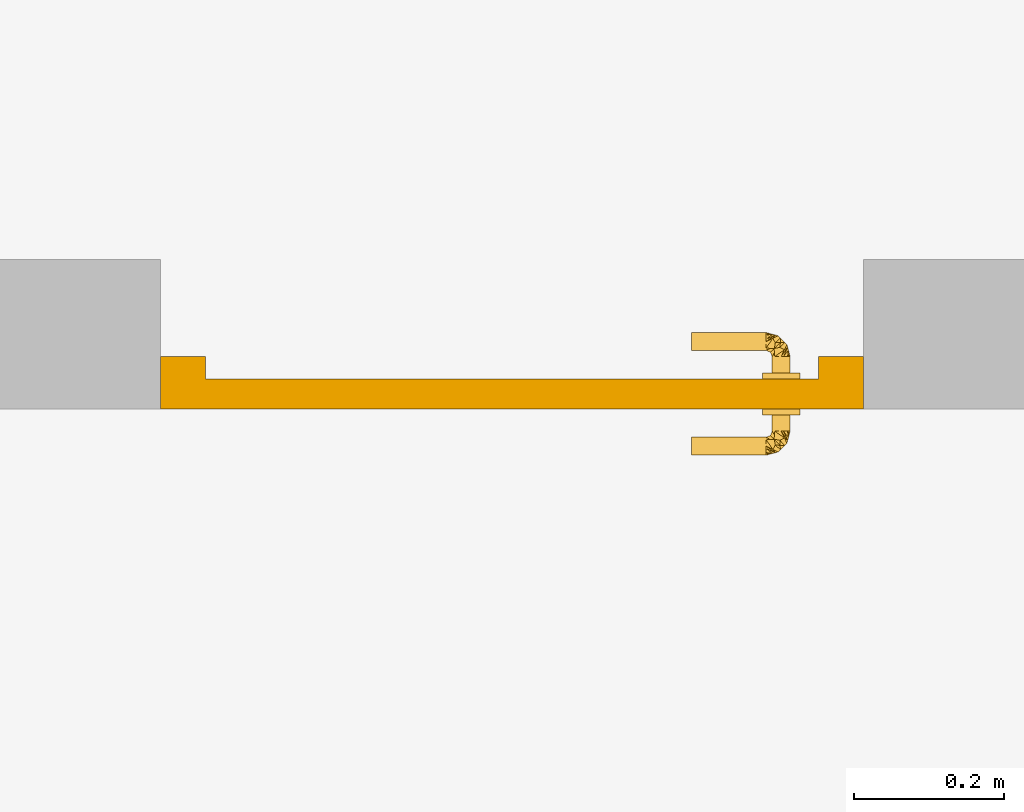
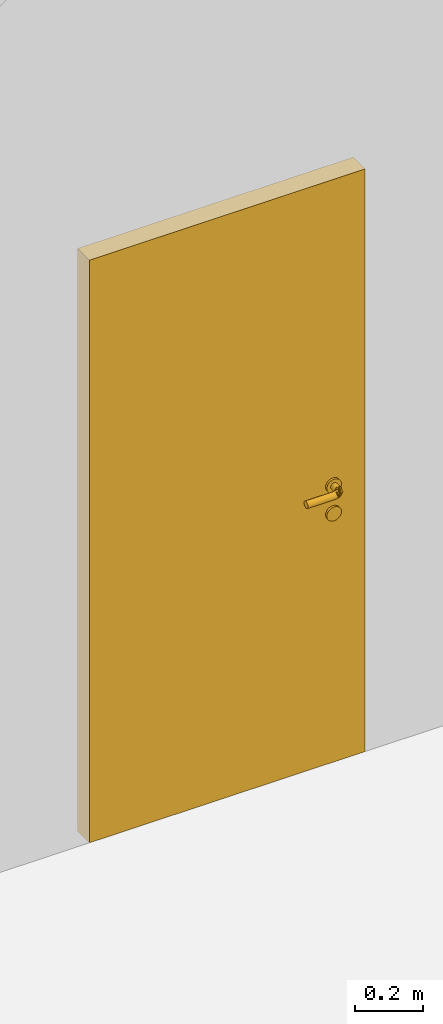
# One storey, part 3 of 4: 1 door.
"""IFC2X3 building model written with IfcOpenShell, lengths in millimetres."""

from ifc_helpers import new_model, entity, si_unit, converted_unit, derived_unit, direction, frame, origin, place, context, subcontext, project, spatial, faceted_brep, source, transform, mapped, material, material_list, type_object, type_shapes, element, save


model = new_model("IFC2X3")

# Units and contexts
model_context = context("Model", 3, precision=0.01, world=origin(), true_north=direction((6.123233995736766e-17, 1.0)))
body_context = subcontext(model_context, "Body", "Model", "MODEL_VIEW")
ifc_project = project(units=[si_unit("LENGTHUNIT", "METRE", prefix="MILLI"), si_unit("AREAUNIT", "SQUARE_METRE"), si_unit("VOLUMEUNIT", "CUBIC_METRE"), converted_unit("PLANEANGLEUNIT", "DEGREE", entity("IfcPlaneAngleMeasure", 0.017453292519943278), si_unit("PLANEANGLEUNIT", "RADIAN"), dimensions=[0, 0, 0, 0, 0, 0, 0]), derived_unit("THERMALTRANSMITTANCEUNIT", [(si_unit("MASSUNIT", "GRAM", prefix="KILO"), 1), (si_unit("THERMODYNAMICTEMPERATUREUNIT", "KELVIN"), -1), (si_unit("TIMEUNIT", "SECOND"), -3)])], contexts=[model_context])

# Site, building, storey
site_placement = place(None, origin())
site = spatial("IfcSite", under=ifc_project, at=site_placement, CompositionType="ELEMENT")
building_placement = place(site_placement, origin())
building = spatial("IfcBuilding", under=site, at=building_placement, CompositionType="ELEMENT")
storey_placement = place(building_placement, origin())
storey = spatial("IfcBuildingStorey", under=building, at=storey_placement, CompositionType="ELEMENT", Elevation=0.0)

# Door
ifc_material_1 = material()
ifc_material_2 = material()
ifc_material_list = material_list([ifc_material_1, ifc_material_2])
door_style = type_object("IfcDoorStyle", ConstructionType="USERDEFINED", OperationType="NOTDEFINED", ParameterTakesPrecedence=False, Sizeable=False, material=ifc_material_list)
shared_shape = source(origin(), body_context, "Body", "Brep", [
    faceted_brep([(121.59110991546477, -492.0, 996.8941714587709), (121.59110991546477, -470.0, 996.8941714587709), (122.0, -470.0, 1000.0), (122.0, -492.0, 1000.0), (122.0, -570.0, 1000.0), (121.59110991546484, -570.0, 996.894171458771), (121.59110991546477, -548.0, 996.8941714587709), (122.0, -548.0, 1000.0), (120.39230484540924, -492.0, 994.0), (120.39230484540924, -470.0, 994.0), (120.39230484540931, -570.0, 994.0), (120.39230484540924, -548.0, 994.0), (118.48528137423456, -470.0, 991.5147186257626), (118.4852813742345, -492.0, 991.5147186257626), (116.0, -492.0, 989.6076951545878), (116.0, -470.0, 989.607695154588), (118.48528137423456, -570.0, 991.5147186257626), (116.0, -570.0, 989.6076951545878), (116.0, -548.0, 989.6076951545878), (118.4852813742345, -548.0, 991.5147186257626), (113.10582854122617, -492.0, 988.4088900845322), (113.10582854122624, -470.0, 988.4088900845322), (113.10582854122612, -570.0, 988.4088900845322), (113.10582854122617, -548.0, 988.4088900845322), (110.0, -492.0, 988.0), (110.0, -470.0, 988.0), (110.0, -570.0, 988.0), (110.0, -548.0, 988.0), (104.0, -492.0, 989.607695154588), (104.0, -470.0, 989.6076951545878), (106.89417145876577, -470.0, 988.4088900845322), (106.89417145876577, -492.0, 988.4088900845322), (106.8941714587655, -570.0, 988.4088900845325), (104.0, -570.0, 989.607695154588), (104.0, -548.0, 989.607695154588), (106.89417145876577, -548.0, 988.4088900845322), (101.51471862575745, -492.0, 991.5147186257626), (101.51471862575745, -470.0, 991.5147186257626), (101.51471862575724, -570.0, 991.5147186257627), (101.51471862575745, -548.0, 991.5147186257626), (99.60769515458277, -470.0, 994.0), (99.6076951545827, -492.0, 994.0), (98.40889008452717, -492.0, 996.8941714587709), (98.40889008452717, -470.0, 996.8941714587709), (99.60769515458257, -570.0, 994.0), (98.4088900845271, -570.0, 996.894171458771), (98.40889008452717, -548.0, 996.8941714587709), (99.6076951545827, -548.0, 994.0), (98.0, -492.0, 1000.0), (98.0, -470.0, 1000.0), (98.0, -570.0, 1000.0), (98.0, -548.0, 1000.0), (98.4088900845271, -492.0, 1003.1058285412312), (98.4088900845271, -470.0, 1003.1058285412312), (98.40889008452717, -570.0, 1003.1058285412314), (98.4088900845271, -548.0, 1003.1058285412312), (99.60769515458257, -492.0, 1006.0), (99.60769515458263, -470.0, 1006.0), (99.60769515458263, -570.0, 1006.0), (99.60769515458257, -548.0, 1006.0), (101.51471862575724, -470.0, 1008.4852813742397), (101.51471862575724, -492.0, 1008.4852813742397), (104.0, -492.0, 1010.3923048454144), (104.0, -470.0, 1010.3923048454144), (101.51471862575724, -548.0, 1008.4852813742397), (101.51471862575731, -570.0, 1008.4852813742397), (104.0, -570.0, 1010.3923048454144), (104.0, -548.0, 1010.3923048454144), (106.8941714587655, -492.0, 1011.5911099154699), (106.89417145876557, -470.0, 1011.5911099154699), (106.89417145876543, -570.0, 1011.5911099154699), (106.8941714587655, -548.0, 1011.5911099154699), (110.0, -492.0, 1012.0), (110.0, -470.0, 1012.0), (110.0, -570.0, 1012.0), (110.0, -548.0, 1012.0), (116.0, -492.0, 1010.3923048454145), (116.0, -470.0, 1010.3923048454145), (113.10582854122605, -470.0, 1011.59110991547), (113.10582854122597, -492.0, 1011.59110991547), (116.0, -570.0, 1010.3923048454146), (116.0, -548.0, 1010.3923048454145), (113.10582854122597, -548.0, 1011.59110991547), (113.10582854122585, -570.0, 1011.59110991547), (118.48528137423436, -492.0, 1008.4852813742399), (118.48528137423443, -470.0, 1008.4852813742399), (118.48528137423423, -570.0, 1008.48528137424), (118.48528137423436, -548.0, 1008.4852813742399), (120.39230484540911, -470.0, 1006.0), (120.39230484540911, -492.0, 1006.0), (121.5911099154647, -492.0, 1003.1058285412317), (121.5911099154647, -470.0, 1003.1058285412317), (120.39230484540911, -548.0, 1006.0), (120.39230484540904, -570.0, 1006.0), (121.5911099154647, -570.0, 1003.1058285412319), (121.5911099154647, -548.0, 1003.1058285412317), (230.0, -456.0, 989.6076951545883), (230.0, -453.10582854122947, 988.4088900845327), (230.0, -450.0, 988.0), (230.0, -446.89417145876905, 988.4088900845327), (230.0, -444.0, 989.6076951545882), (230.0, -441.5147186257607, 991.514718625763), (230.0, -439.607695154586, 994.0), (230.0, -438.4088900845304, 996.8941714587711), (230.0, -438.0, 1000.0), (230.0, -438.40889008453036, 1003.1058285412317), (230.0, -439.6076951545859, 1006.0), (230.0, -441.51471862576057, 1008.48528137424), (230.0, -444.0, 1010.3923048454147), (230.0, -446.8941714587688, 1011.5911099154703), (230.0, -450.0, 1012.0), (230.0, -453.1058285412293, 1011.5911099154704), (230.0, -456.0, 1010.3923048454149), (230.0, -458.4852813742377, 1008.4852813742401), (230.0, -460.39230484541235, 1006.0), (230.0, -461.59110991546794, 1003.105828541232), (230.0, -462.0, 1000.0), (230.0, -461.591109915468, 996.8941714587714), (230.0, -460.39230484541247, 994.0), (230.0, -458.4852813742378, 991.5147186257631), (230.0, -590.0, 988.0), (230.0, -586.8941714587676, 988.4088900845326), (230.0, -584.0, 989.6076951545882), (230.0, -581.5147186257592, 991.5147186257628), (230.0, -579.6076951545846, 994.0), (230.0, -578.408890084529, 996.8941714587711), (230.0, -578.0, 1000.0), (230.0, -578.408890084529, 1003.1058285412319), (230.0, -579.6076951545847, 1006.0), (230.0, -581.5147186257594, 1008.48528137424), (230.0, -584.0, 1010.3923048454147), (230.0, -586.8941714587677, 1011.5911099154703), (230.0, -590.0, 1012.0), (230.0, -593.1058285412282, 1011.5911099154702), (230.0, -596.0, 1010.3923048454146), (230.0, -598.4852813742365, 1008.4852813742399), (230.0, -600.3923048454112, 1006.0), (230.0, -601.5911099154667, 1003.1058285412315), (230.0, -602.0, 1000.0), (230.0, -601.5911099154666, 996.8941714587711), (230.0, -600.3923048454111, 994.0), (230.0, -598.4852813742365, 991.5147186257628), (230.0, -596.0, 989.6076951545881), (230.0, -593.1058285412281, 988.4088900845326), (130.0, -438.40889008453036, 1003.1058285412314), (130.0, -438.0, 1000.0), (130.0, -439.6076951545859, 1006.0), (130.0, -441.51471862576057, 1008.4852813742398), (130.0, -444.0, 1010.3923048454145), (130.0, -446.8941714587688, 1011.59110991547), (130.0, -450.0, 1012.0), (130.0, -453.10582854122924, 1011.5911099154702), (130.0, -456.0, 1010.3923048454146), (130.0, -458.4852813742377, 1008.48528137424), (130.0, -460.39230484541235, 1006.0), (130.0, -461.59110991546794, 1003.1058285412317), (130.0, -462.0, 1000.0), (130.0, -461.591109915468, 996.894171458771), (130.0, -460.39230484541247, 994.0), (130.0, -458.4852813742378, 991.5147186257627), (130.0, -456.0, 989.6076951545881), (130.0, -453.10582854122947, 988.4088900845325), (130.0, -450.0, 988.0), (130.0, -444.0, 989.607695154588), (130.0, -446.894171458769, 988.4088900845325), (130.0, -441.5147186257607, 991.5147186257627), (130.0, -439.60769515458594, 994.0), (130.0, -438.4088900845304, 996.894171458771), (127.87793408593642, -438.56860584795703, 1000.0), (117.75586817187694, -441.2808052353638, 1000.0), (111.37049257418172, -451.08306038662926, 1010.0546436581552), (105.21539030916938, -451.0717967697236, 1000.0), (111.69397506659625, -457.8110403797383, 1011.8333818637104), (121.0996317232342, -445.7123106737361, 1010.467893148177), (121.51173634375786, -440.27442339183057, 1000.0), (125.75586817187694, -439.1372116959149, 1000.0), (124.34314575050354, -464.3431457505068, 1000.0), (119.2508044309217, -464.7237027643928, 1008.9212431944304), (114.0, -442.2871870788971, 1000.0), (117.81104088414693, -451.69397564576747, 1011.8333819919711), (124.72370261485119, -459.25080409009576, 1008.9212435289514), (108.14359353944491, -448.1435935394481, 1000.0), (111.07179676972042, -445.2153903091726, 1000.0), (119.28684519631864, -459.2868447854793, 1010.9765287722931), (98.56860585200525, -467.8779340708194, 1000.0), (101.28080524346359, -457.7558681416396, 1000.0), (100.27442340803319, -461.51173628328013, 1000.0), (99.13721170401456, -465.7558681416396, 1000.0), (105.69502649426845, -461.0754037172244, 1010.454083649859), (102.28718707889392, -454.0, 1000.0), (121.09963172318527, -445.7123106737106, 989.5321068518484), (111.08306080364964, -451.37049209046614, 989.9453563693929), (111.69397506603323, -457.81104037871506, 988.1666181364666), (119.28684519598383, -459.2868447850599, 989.0234712274738), (124.72370261480219, -459.25080409001765, 991.0787564709686), (117.81104088399486, -451.6939756456266, 988.1666180080653), (119.25080443087481, -464.7237027644061, 991.0787568055393), (105.69502649422013, -461.0754037171189, 989.5459163501895), (98.56860584795362, -572.1220659140577, 1000.0), (101.28080523536036, -582.2441318281171, 1000.0), (111.08306038662634, -588.6295074258122, 1010.0546436581567), (111.07179676972015, -594.7846096908246, 1000.0), (117.81104037973532, -588.3060249333975, 1011.8333818637116), (105.7123106737326, -578.9003682767598, 1010.467893148178), (100.27442339182713, -578.4882636562362, 1000.0), (99.13721169591146, -574.2441318281171, 1000.0), (130.0, -578.0, 1000.0), (124.34314575050334, -575.6568542494905, 1000.0), (124.72370276438959, -580.7491955690724, 1008.9212431944316), (102.2871870788936, -586.0, 1000.0), (111.69397564576394, -582.1889591158472, 1011.8333819919721), (119.25080409009226, -575.2762973851428, 1008.9212435289525), (108.14359353944464, -591.856406460549, 1000.0), (105.21539030916911, -588.9282032302735, 1000.0), (119.28684478547648, -580.7131548036747, 1010.9765287722937), (130.0, -600.3923048454116, 1006.0), (127.87793407081594, -601.4313941479888, 1000.0), (130.0, -601.5911099154671, 1003.1058285412322), (130.0, -593.1058285412284, 1011.5911099154712), (117.75586814163617, -598.7191947565306, 1000.0), (121.51173628327682, -599.7255765919609, 1000.0), (125.75586814163626, -600.8627882959795, 1000.0), (121.07540371722092, -594.3049735057256, 1010.4540836498602), (114.0, -597.7128129211001, 1000.0), (130.0, -581.5147186257594, 1008.4852813742408), (130.0, -584.0, 1010.3923048454155), (130.0, -596.0, 1010.3923048454155), (130.0, -590.0, 1012.0), (130.0, -598.4852813742368, 1008.4852813742408), (130.0, -602.0, 1000.0), (130.0, -578.4088900845293, 1003.1058285412325), (130.0, -579.6076951545848, 1006.0), (130.0, -586.8941714587678, 1011.5911099154712), (105.71231067370717, -578.9003682768089, 989.5321068518496), (111.37049209046316, -588.9169391963447, 989.9453563693941), (117.81104037871228, -588.3060249339608, 988.1666181364676), (119.2868447850568, -580.7131548040102, 989.023471227475), (119.25080409001423, -575.2762973851919, 991.0787564709696), (111.69397564562311, -582.1889591159994, 988.1666180080664), (130.0, -601.5911099154669, 996.8941714587718), (124.72370276440299, -580.7491955691194, 991.0787568055406), (130.0, -590.0, 988.0), (130.0, -593.1058285412281, 988.4088900845335), (121.07540371711555, -594.304973505774, 989.5459163501906), (130.0, -578.4088900845294, 996.894171458772), (130.0, -579.6076951545849, 994.0), (130.0, -598.4852813742365, 991.5147186257635), (130.0, -581.5147186257595, 991.5147186257637), (130.0, -586.8941714587678, 988.4088900845336), (130.0, -584.0, 989.6076951545891), (130.0, -600.3923048454112, 994.0), (130.0, -596.0, 989.6076951545889), (122.49999999999916, -492.0, 1021.6506350946136), (127.67766952966286, -492.0, 1017.6776695296661), (116.4704761275622, -492.0, 1024.1481456572292), (110.0, -492.0, 1025.0), (103.52952387243619, -492.0, 1024.1481456572292), (97.49999999999922, -492.0, 1021.6506350946136), (92.32233047033552, -492.0, 1017.6776695296663), (88.3493649053882, -492.0, 1012.5000000000025), (85.85185434277247, -492.0, 1006.4704761275656), (85.0, -492.0, 1000.0), (85.85185434277241, -492.0, 993.5295238724397), (88.34936490538813, -492.0, 987.5000000000026), (92.32233047033537, -492.0, 982.3223304703389), (97.49999999999909, -492.0, 978.3493649053917), (103.52952387243604, -492.0, 975.8518543427758), (110.0, -492.0, 975.0), (116.47047612756205, -492.0, 975.8518543427758), (122.49999999999902, -492.0, 978.3493649053914), (127.67766952966274, -492.0, 982.3223304703387), (131.65063509461004, -492.0, 987.5000000000024), (134.14814565722583, -492.0, 993.5295238724393), (135.0, -492.0, 1000.0), (134.14814565722583, -492.0, 1006.4704761275656), (131.65063509461018, -492.0, 1012.5000000000025), (122.49999999999902, -548.0, 978.3493649053914), (127.67766952966274, -548.0, 982.3223304703387), (116.47047612756205, -548.0, 975.8518543427758), (110.0, -548.0, 975.0), (103.52952387243604, -548.0, 975.8518543427758), (97.49999999999909, -548.0, 978.3493649053917), (92.32233047033537, -548.0, 982.3223304703389), (88.34936490538813, -548.0, 987.5000000000026), (85.85185434277241, -548.0, 993.5295238724397), (85.0, -548.0, 1000.0), (85.85185434277247, -548.0, 1006.4704761275656), (88.3493649053882, -548.0, 1012.5000000000025), (92.32233047033552, -548.0, 1017.6776695296663), (97.49999999999922, -548.0, 1021.6506350946136), (103.52952387243619, -548.0, 1024.1481456572292), (110.0, -548.0, 1025.0), (116.4704761275622, -548.0, 1024.1481456572292), (122.49999999999916, -548.0, 1021.6506350946136), (127.67766952966286, -548.0, 1017.6776695296661), (131.65063509461018, -548.0, 1012.5000000000025), (134.14814565722583, -548.0, 1006.4704761275656), (135.0, -548.0, 1000.0), (134.14814565722583, -548.0, 993.5295238724393), (131.65063509461004, -548.0, 987.5000000000024)], [[[0, 1, 2, 3]], [[4, 5, 6, 7]], [[8, 9, 1, 0]], [[5, 10, 11, 6]], [[12, 13, 14, 15]], [[16, 17, 18, 19]], [[8, 13, 12, 9]], [[10, 16, 19, 11]], [[15, 14, 20, 21]], [[17, 22, 23, 18]], [[21, 20, 24, 25]], [[26, 27, 23, 22]], [[28, 29, 30, 31]], [[32, 33, 34, 35]], [[36, 37, 29, 28]], [[33, 38, 39, 34]], [[40, 41, 42, 43]], [[44, 45, 46, 47]], [[36, 41, 40, 37]], [[38, 44, 47, 39]], [[43, 42, 48, 49]], [[45, 50, 51, 46]], [[30, 25, 24, 31]], [[35, 27, 26, 32]], [[52, 53, 49, 48]], [[54, 55, 51, 50]], [[56, 57, 53, 52]], [[58, 59, 55, 54]], [[60, 61, 62, 63]], [[64, 65, 66, 67]], [[56, 61, 60, 57]], [[58, 65, 64, 59]], [[63, 62, 68, 69]], [[67, 66, 70, 71]], [[69, 68, 72, 73]], [[74, 75, 71, 70]], [[76, 77, 78, 79]], [[80, 81, 82, 83]], [[84, 85, 77, 76]], [[86, 87, 81, 80]], [[88, 89, 90, 91]], [[92, 93, 94, 95]], [[84, 89, 88, 85]], [[86, 93, 92, 87]], [[91, 90, 3, 2]], [[95, 94, 4, 7]], [[78, 73, 72, 79]], [[82, 75, 74, 83]], [[96, 97, 98, 99, 100, 101, 102, 103, 104, 105, 106, 107, 108, 109, 110, 111, 112, 113, 114, 115, 116, 117, 118, 119]], [[120, 121, 122, 123, 124, 125, 126, 127, 128, 129, 130, 131, 132, 133, 134, 135, 136, 137, 138, 139, 140, 141, 142, 143]], [[144, 105, 104, 145]], [[146, 106, 105, 144]], [[107, 147, 148, 108]], [[146, 147, 107, 106]], [[108, 148, 149, 109]], [[109, 149, 150, 110]], [[111, 151, 152, 112]], [[153, 113, 112, 152]], [[114, 154, 155, 115]], [[153, 154, 114, 113]], [[115, 155, 156, 116]], [[111, 110, 150, 151]], [[157, 117, 116, 156]], [[158, 118, 117, 157]], [[119, 159, 160, 96]], [[158, 159, 119, 118]], [[96, 160, 161, 97]], [[97, 161, 162, 98]], [[163, 100, 99, 164]], [[165, 101, 100, 163]], [[102, 166, 167, 103]], [[165, 166, 102, 101]], [[103, 167, 145, 104]], [[99, 98, 162, 164]], [[144, 168, 146]], [[149, 169, 150]], [[170, 171, 172]], [[152, 151, 173]], [[174, 148, 147]], [[146, 175, 147]], [[2, 176, 177]], [[148, 174, 149]], [[178, 173, 169]], [[173, 179, 180]], [[149, 174, 169]], [[181, 171, 170, 182]], [[169, 173, 150]], [[173, 151, 150]], [[176, 156, 180]], [[179, 170, 183]], [[57, 184, 53]], [[69, 185, 186]], [[187, 184, 57]], [[153, 180, 154]], [[173, 153, 152]], [[188, 172, 189]], [[85, 188, 77]], [[176, 183, 177]], [[180, 153, 173]], [[176, 180, 183]], [[186, 63, 69]], [[179, 178, 182]], [[185, 73, 188]], [[187, 60, 186]], [[69, 73, 185]], [[186, 60, 63]], [[171, 189, 172]], [[53, 184, 49]], [[91, 2, 177]], [[188, 189, 185]], [[174, 147, 175]], [[180, 156, 155]], [[179, 173, 178]], [[172, 188, 177]], [[187, 57, 60]], [[91, 177, 88]], [[172, 177, 183]], [[85, 177, 188]], [[168, 175, 146]], [[88, 177, 85]], [[144, 145, 168]], [[77, 188, 78]], [[73, 78, 188]], [[170, 172, 183]], [[170, 179, 182]], [[155, 154, 180]], [[180, 179, 183]], [[190, 161, 160]], [[191, 192, 171]], [[176, 193, 194]], [[190, 159, 194]], [[190, 194, 195]], [[43, 49, 184]], [[159, 158, 194]], [[169, 174, 164]], [[157, 194, 158]], [[169, 162, 190]], [[195, 194, 193]], [[193, 196, 192]], [[168, 145, 167]], [[182, 178, 195]], [[165, 174, 175]], [[164, 162, 169]], [[25, 30, 185]], [[174, 165, 163]], [[163, 164, 174]], [[181, 182, 191, 171]], [[185, 189, 197]], [[193, 191, 195]], [[2, 1, 196]], [[9, 196, 1]], [[190, 195, 178]], [[186, 37, 187]], [[192, 197, 189]], [[197, 196, 12]], [[175, 166, 165]], [[21, 197, 15]], [[184, 187, 40]], [[175, 168, 166]], [[197, 12, 15]], [[12, 196, 9]], [[21, 25, 197]], [[192, 189, 171]], [[156, 194, 157]], [[29, 37, 186]], [[186, 30, 29]], [[176, 2, 196]], [[185, 30, 186]], [[40, 43, 184]], [[191, 182, 195]], [[25, 185, 197]], [[197, 192, 196]], [[159, 190, 160]], [[40, 187, 37]], [[192, 191, 193]], [[166, 168, 167]], [[156, 176, 194]], [[169, 190, 178]], [[193, 176, 196]], [[190, 162, 161]], [[54, 198, 58]], [[70, 199, 74]], [[200, 201, 202]], [[80, 83, 203]], [[204, 66, 65]], [[58, 205, 65]], [[206, 207, 208]], [[66, 204, 70]], [[209, 203, 199]], [[203, 210, 211]], [[70, 204, 199]], [[212, 201, 200, 213]], [[199, 203, 74]], [[203, 83, 74]], [[207, 4, 211]], [[210, 200, 214]], [[215, 216, 217]], [[218, 219, 220]], [[221, 216, 215]], [[86, 211, 93]], [[203, 86, 80]], [[222, 202, 223]], [[224, 222, 225]], [[207, 214, 208]], [[211, 86, 203]], [[207, 211, 214]], [[220, 226, 218]], [[210, 209, 213]], [[219, 227, 222]], [[221, 228, 220]], [[218, 227, 219]], [[220, 228, 226]], [[201, 223, 202]], [[217, 216, 229]], [[230, 206, 208]], [[222, 223, 219]], [[204, 65, 205]], [[211, 4, 94]], [[210, 203, 209]], [[202, 222, 208]], [[221, 215, 228]], [[230, 208, 231]], [[202, 208, 214]], [[224, 208, 222]], [[198, 205, 58]], [[231, 208, 224]], [[54, 50, 198]], [[225, 222, 232]], [[227, 232, 222]], [[200, 202, 214]], [[200, 210, 213]], [[94, 93, 211]], [[211, 210, 214]], [[233, 22, 17]], [[234, 235, 201]], [[207, 236, 237]], [[233, 16, 237]], [[233, 237, 238]], [[239, 229, 216]], [[16, 10, 237]], [[199, 204, 32]], [[5, 237, 10]], [[199, 26, 233]], [[238, 237, 236]], [[236, 240, 235]], [[198, 50, 45]], [[213, 209, 238]], [[38, 204, 205]], [[32, 26, 199]], [[241, 242, 219]], [[204, 38, 33]], [[33, 32, 204]], [[212, 213, 234, 201]], [[219, 223, 243]], [[236, 234, 238]], [[206, 244, 240]], [[245, 240, 244]], [[233, 238, 209]], [[220, 246, 221]], [[235, 243, 223]], [[243, 240, 247]], [[205, 44, 38]], [[248, 243, 249]], [[216, 221, 250]], [[205, 198, 44]], [[243, 247, 249]], [[247, 240, 245]], [[248, 241, 243]], [[235, 223, 201]], [[4, 237, 5]], [[251, 246, 220]], [[220, 242, 251]], [[207, 206, 240]], [[219, 242, 220]], [[250, 239, 216]], [[234, 213, 238]], [[241, 219, 243]], [[243, 235, 240]], [[16, 233, 17]], [[250, 221, 246]], [[235, 234, 236]], [[44, 198, 45]], [[4, 207, 237]], [[199, 233, 209]], [[236, 207, 240]], [[233, 26, 22]], [[137, 217, 229, 138]], [[136, 215, 217, 137]], [[228, 135, 134, 226]], [[136, 135, 228, 215]], [[226, 134, 133, 218]], [[218, 133, 132, 227]], [[232, 131, 130, 225]], [[129, 224, 225, 130]], [[231, 128, 127, 230]], [[129, 128, 231, 224]], [[230, 127, 126, 206]], [[232, 227, 132, 131]], [[206, 126, 125, 244]], [[124, 245, 244, 125]], [[247, 123, 122, 249]], [[245, 124, 123, 247]], [[249, 122, 121, 248]], [[248, 121, 120, 241]], [[142, 141, 246, 251]], [[143, 142, 251, 242]], [[139, 138, 229, 239]], [[140, 139, 239, 250]], [[141, 140, 250, 246]], [[242, 241, 120, 143]], [[76, 79, 252]], [[253, 76, 252]], [[76, 253, 84]], [[79, 254, 252]], [[254, 79, 72]], [[254, 72, 255]], [[68, 255, 72]], [[255, 68, 256]], [[68, 62, 256]], [[257, 256, 62]], [[61, 257, 62]], [[257, 61, 258]], [[56, 258, 61]], [[259, 258, 56]], [[52, 259, 56]], [[260, 259, 52]], [[260, 52, 48]], [[260, 48, 261]], [[261, 48, 42]], [[261, 42, 262]], [[262, 42, 41]], [[262, 41, 263]], [[264, 263, 41]], [[264, 41, 36]], [[36, 265, 264]], [[36, 28, 265]], [[266, 265, 28]], [[31, 266, 28]], [[31, 267, 266]], [[267, 31, 24]], [[24, 268, 267]], [[20, 268, 24]], [[268, 20, 269]], [[14, 269, 20]], [[270, 269, 14]], [[270, 14, 13]], [[270, 13, 271]], [[271, 13, 8]], [[271, 8, 272]], [[0, 272, 8]], [[273, 272, 0]], [[0, 3, 273]], [[3, 274, 273]], [[274, 3, 90]], [[274, 90, 275]], [[90, 89, 275]], [[84, 275, 89]], [[253, 275, 84]], [[18, 23, 276]], [[277, 18, 276]], [[18, 277, 19]], [[23, 278, 276]], [[278, 23, 27]], [[278, 27, 279]], [[35, 279, 27]], [[279, 35, 280]], [[35, 34, 280]], [[281, 280, 34]], [[39, 281, 34]], [[281, 39, 282]], [[47, 282, 39]], [[283, 282, 47]], [[46, 283, 47]], [[284, 283, 46]], [[284, 46, 51]], [[284, 51, 285]], [[285, 51, 55]], [[285, 55, 286]], [[286, 55, 59]], [[286, 59, 287]], [[288, 287, 59]], [[288, 59, 64]], [[64, 289, 288]], [[64, 67, 289]], [[290, 289, 67]], [[71, 290, 67]], [[71, 291, 290]], [[291, 71, 75]], [[75, 292, 291]], [[82, 292, 75]], [[292, 82, 293]], [[81, 293, 82]], [[294, 293, 81]], [[294, 81, 87]], [[294, 87, 295]], [[295, 87, 92]], [[295, 92, 296]], [[95, 296, 92]], [[297, 296, 95]], [[95, 7, 297]], [[7, 298, 297]], [[298, 7, 6]], [[298, 6, 299]], [[6, 11, 299]], [[19, 299, 11]], [[277, 299, 19]], [[284, 262, 263, 283]], [[264, 282, 283, 263]], [[281, 265, 266, 280]], [[264, 265, 281, 282]], [[280, 266, 267, 279]], [[262, 284, 285, 261]], [[278, 268, 269, 276]], [[270, 277, 276, 269]], [[299, 271, 272, 298]], [[270, 271, 299, 277]], [[298, 272, 273, 297]], [[268, 278, 279, 267]], [[296, 297, 273, 274]], [[275, 295, 296, 274]], [[293, 252, 254, 292]], [[292, 254, 255, 291]], [[294, 253, 252, 293]], [[294, 295, 275, 253]], [[290, 256, 257, 289]], [[258, 288, 289, 257]], [[287, 259, 260, 286]], [[258, 259, 287, 288]], [[286, 260, 261, 285]], [[256, 290, 291, 255]]]),
    faceted_brep([(116.47047612756226, -492.0, 924.1481456572286), (122.49999999999929, -492.0, 921.650635094613), (127.67766952966294, -492.0, 917.6776695296656), (131.65063509461018, -492.0, 912.5000000000019), (134.14814565722597, -492.0, 906.470476127565), (135.0, -492.0, 900.0), (134.1481456572259, -492.0, 893.5295238724387), (131.6506350946101, -492.0, 887.5000000000018), (127.6776695296628, -492.0, 882.3223304703382), (122.49999999999916, -492.0, 878.349364905391), (116.47047612756212, -492.0, 875.8518543427753), (110.0, -492.0, 875.0), (103.52952387243612, -492.0, 875.8518543427753), (97.49999999999915, -492.0, 878.3493649053911), (92.32233047033552, -492.0, 882.3223304703383), (88.3493649053882, -492.0, 887.500000000002), (85.85185434277247, -492.0, 893.5295238724391), (85.0, -492.0, 900.0), (85.85185434277254, -492.0, 906.470476127565), (88.34936490538827, -492.0, 912.5000000000019), (92.32233047033557, -492.0, 917.6776695296658), (97.49999999999929, -492.0, 921.650635094613), (103.52952387243626, -492.0, 924.1481456572286), (110.0, -492.0, 925.0), (116.47047612756212, -548.0, 875.8518543427753), (122.49999999999916, -548.0, 878.349364905391), (127.6776695296628, -548.0, 882.3223304703382), (131.6506350946101, -548.0, 887.5000000000018), (134.1481456572259, -548.0, 893.5295238724387), (135.0, -548.0, 900.0), (134.14814565722597, -548.0, 906.470476127565), (131.65063509461018, -548.0, 912.5000000000019), (127.67766952966294, -548.0, 917.6776695296656), (122.49999999999929, -548.0, 921.650635094613), (116.47047612756226, -548.0, 924.1481456572286), (110.0, -548.0, 925.0), (103.52952387243626, -548.0, 924.1481456572286), (97.49999999999929, -548.0, 921.650635094613), (92.32233047033557, -548.0, 917.6776695296658), (88.34936490538827, -548.0, 912.5000000000019), (85.85185434277254, -548.0, 906.470476127565), (85.0, -548.0, 900.0), (85.85185434277247, -548.0, 893.5295238724391), (88.3493649053882, -548.0, 887.500000000002), (92.32233047033552, -548.0, 882.3223304703383), (97.49999999999915, -548.0, 878.3493649053911), (103.52952387243612, -548.0, 875.8518543427753), (110.0, -548.0, 875.0)], [[[0, 1, 2, 3, 4, 5, 6, 7, 8, 9, 10, 11, 12, 13, 14, 15, 16, 17, 18, 19, 20, 21, 22, 23]], [[24, 25, 26, 27, 28, 29, 30, 31, 32, 33, 34, 35, 36, 37, 38, 39, 40, 41, 42, 43, 44, 45, 46, 47]], [[42, 16, 15, 43]], [[14, 44, 43, 15]], [[45, 13, 12, 46]], [[14, 13, 45, 44]], [[46, 12, 11, 47]], [[16, 42, 41, 17]], [[24, 10, 9, 25]], [[8, 26, 25, 9]], [[27, 7, 6, 28]], [[8, 7, 27, 26]], [[28, 6, 5, 29]], [[10, 24, 47, 11]], [[30, 29, 5, 4]], [[3, 31, 30, 4]], [[33, 1, 0, 34]], [[34, 0, 23, 35]], [[32, 2, 1, 33]], [[32, 31, 3, 2]], [[36, 22, 21, 37]], [[20, 38, 37, 21]], [[39, 19, 18, 40]], [[20, 19, 39, 38]], [[40, 18, 17, 41]], [[22, 36, 35, 23]]]),
    faceted_brep([(890.0, -540.0, 2050.0), (50.0, -540.0, 2050.0), (50.0, -540.0, 0.0), (890.0, -540.0, 0.0), (890.0, -500.0, 2050.0), (890.0, -500.0, 0.0), (50.0, -500.0, 0.0), (50.0, -500.0, 2050.0)], [[[0, 1, 2, 3]], [[4, 5, 6, 7]], [[1, 0, 4, 7]], [[2, 1, 7, 6]], [[3, 2, 6, 5]], [[0, 3, 5, 4]]]),
    faceted_brep([(940.0, -570.0, 0.0), (940.0, -570.0, 2100.0), (0.0, -570.0, 2100.0), (0.0, -570.0, 0.0), (20.0, -570.0, 0.0), (20.0, -570.0, 2080.0), (920.0, -570.0, 2080.0), (920.0, -570.0, 0.0), (940.0, -500.0, 0.0), (920.0, -500.0, 0.0), (920.0, -500.0, 2080.0), (20.0, -500.0, 2080.0), (20.0, -500.0, 0.0), (0.0, -500.0, 0.0), (0.0, -500.0, 2100.0), (940.0, -500.0, 2100.0)], [[[0, 1, 2, 3, 4, 5, 6, 7]], [[8, 9, 10, 11, 12, 13, 14, 15]], [[9, 8, 0, 7]], [[10, 9, 7, 6]], [[11, 10, 6, 5]], [[12, 11, 5, 4]], [[13, 12, 4, 3]], [[14, 13, 3, 2]], [[15, 14, 2, 1]], [[8, 15, 1, 0]]]),
    faceted_brep([(20.0, -570.0, 0.0), (20.0, -500.0, 0.0), (50.0, -500.0, 0.0), (50.0, -540.0, 0.0), (60.0, -540.0, 0.0), (60.0, -570.0, 0.0), (20.0, -570.0, 2080.0), (20.0, -500.0, 2080.0), (920.0, -500.0, 2080.0), (920.0, -500.0, 0.0), (890.0, -500.0, 0.0), (890.0, -500.0, 2050.0), (50.0, -500.0, 2050.0), (50.0, -540.0, 2050.0), (890.0, -540.0, 2050.0), (890.0, -540.0, 0.0), (880.0, -540.0, 0.0), (880.0, -540.0, 2040.0), (60.0, -540.0, 2040.0), (60.0, -570.0, 2040.0), (880.0, -570.0, 2040.0), (880.0, -570.0, 0.0), (920.0, -570.0, 0.0), (920.0, -570.0, 2080.0)], [[[0, 1, 2, 3, 4, 5]], [[1, 0, 6, 7]], [[2, 1, 7, 8, 9, 10, 11, 12]], [[3, 2, 12, 13]], [[4, 3, 13, 14, 15, 16, 17, 18]], [[5, 4, 18, 19]], [[0, 5, 19, 20, 21, 22, 23, 6]], [[7, 6, 23, 8]], [[13, 12, 11, 14]], [[19, 18, 17, 20]], [[22, 21, 16, 15, 10, 9]], [[8, 23, 22, 9]], [[14, 11, 10, 15]], [[20, 17, 16, 21]]]),
])
type_shapes(door_style, [shared_shape])
door_placement = place(storey_placement, frame((8450.0, 3640.0, 0.0), z_axis=(0.0, 0.0, 1.0), x_axis=(-1.0, 0.0, 0.0)))
element("IfcDoor", 1, at=door_placement, inside=storey, type_object=door_style, material=ifc_material_list, OverallHeight=2100.0, OverallWidth=940.0000000000077, context=body_context, shape_type="MappedRepresentation", body=[
    mapped(shared_shape, transform((0.0, 0.0, 0.0), scale=1.0)),
])

save(model, "model.ifc")
